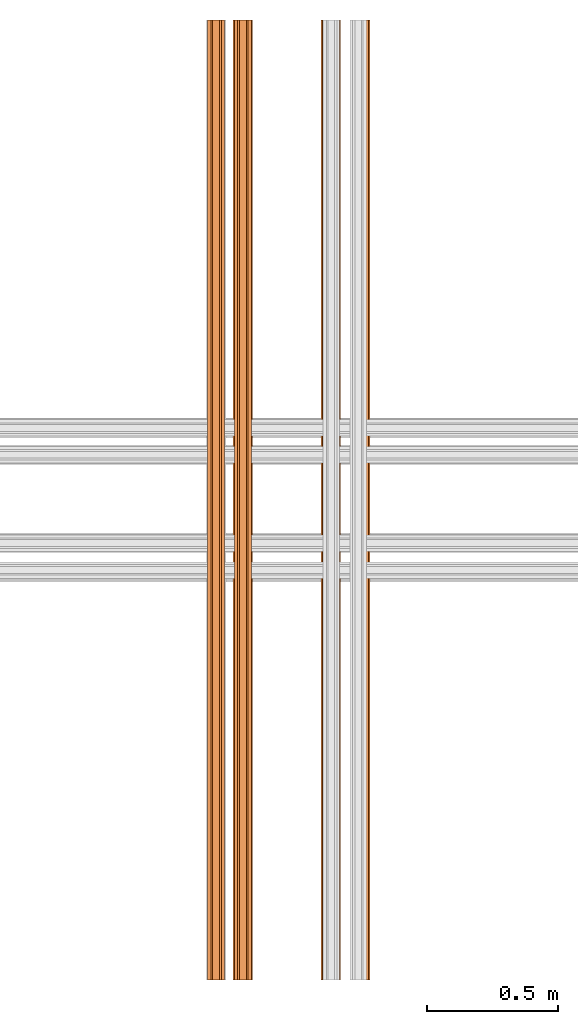
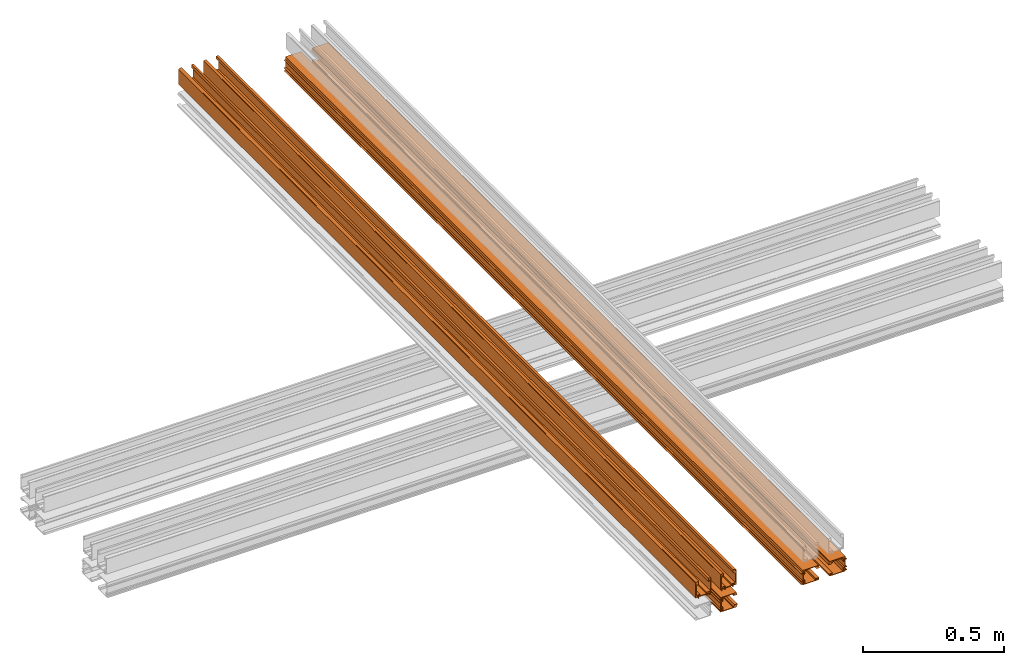
# One storey, part 3 of 4: 5 proxies.
"""IFC2X3 building model written with IfcOpenShell, lengths in feet."""

from ifc_helpers import new_model, entity, si_unit, converted_unit, derived_unit, direction, frame, origin, place, context, subcontext, project, spatial, polyline, outline, extrude, source, transform, mapped, material, type_object, type_shapes, element, save


model = new_model("IFC2X3")

# Units and contexts
model_context = context("Model", 3, precision=0.0001, world=origin(), true_north=direction((6.12303176911189e-17, 1.0)))
body_context = subcontext(model_context, "Body", "Model", "MODEL_VIEW")
ifc_project = project(units=[converted_unit("LENGTHUNIT", "FOOT", entity("IfcRatioMeasure", 0.3048), si_unit("LENGTHUNIT", "METRE"), dimensions=[1, 0, 0, 0, 0, 0, 0]), converted_unit("AREAUNIT", "SQUARE FOOT", entity("IfcRatioMeasure", 0.09290304), si_unit("AREAUNIT", "SQUARE_METRE"), dimensions=[2, 0, 0, 0, 0, 0, 0]), converted_unit("VOLUMEUNIT", "CUBIC FOOT", entity("IfcRatioMeasure", 0.028316846592), si_unit("VOLUMEUNIT", "CUBIC_METRE"), dimensions=[3, 0, 0, 0, 0, 0, 0]), converted_unit("PLANEANGLEUNIT", "DEGREE", entity("IfcRatioMeasure", 0.0174532925199433), si_unit("PLANEANGLEUNIT", "RADIAN"), dimensions=[0, 0, 0, 0, 0, 0, 0]), si_unit("MASSUNIT", "GRAM", prefix="KILO"), derived_unit("MASSDENSITYUNIT", [(si_unit("MASSUNIT", "GRAM", prefix="KILO"), 1), (si_unit("LENGTHUNIT", "METRE"), -3)]), si_unit("TIMEUNIT", "SECOND"), si_unit("FREQUENCYUNIT", "HERTZ"), si_unit("THERMODYNAMICTEMPERATUREUNIT", "DEGREE_CELSIUS"), derived_unit("THERMALTRANSMITTANCEUNIT", [(si_unit("MASSUNIT", "GRAM", prefix="KILO"), 1), (si_unit("THERMODYNAMICTEMPERATUREUNIT", "KELVIN"), -1), (si_unit("TIMEUNIT", "SECOND"), -3)]), derived_unit("VOLUMETRICFLOWRATEUNIT", [(si_unit("LENGTHUNIT", "METRE"), 3), (si_unit("TIMEUNIT", "SECOND"), -1)]), si_unit("ELECTRICCURRENTUNIT", "AMPERE"), si_unit("ELECTRICVOLTAGEUNIT", "VOLT"), si_unit("POWERUNIT", "WATT"), si_unit("FORCEUNIT", "NEWTON"), si_unit("ILLUMINANCEUNIT", "LUX"), si_unit("LUMINOUSFLUXUNIT", "LUMEN"), si_unit("LUMINOUSINTENSITYUNIT", "CANDELA"), derived_unit("USERDEFINED", [(si_unit("MASSUNIT", "GRAM", prefix="KILO"), -1), (si_unit("LENGTHUNIT", "METRE"), -2), (si_unit("TIMEUNIT", "SECOND"), 3), (si_unit("LUMINOUSFLUXUNIT", "LUMEN"), 1)]), derived_unit("LINEARVELOCITYUNIT", [(si_unit("LENGTHUNIT", "METRE"), 1), (si_unit("TIMEUNIT", "SECOND"), -1)]), si_unit("PRESSUREUNIT", "PASCAL"), derived_unit("USERDEFINED", [(si_unit("LENGTHUNIT", "METRE"), -2), (si_unit("MASSUNIT", "GRAM", prefix="KILO"), 1), (si_unit("TIMEUNIT", "SECOND"), -2)])], contexts=[model_context])

# Site, building, storey
site_placement = place(None, origin())
site = spatial("IfcSite", under=ifc_project, at=site_placement, CompositionType="ELEMENT")
building_placement = place(site_placement, origin())
building = spatial("IfcBuilding", under=site, at=building_placement, CompositionType="ELEMENT")
storey_placement = place(building_placement, origin())
storey = spatial("IfcBuildingStorey", under=building, at=storey_placement, Name="Level 1", CompositionType="ELEMENT", Elevation=0.0)

# Proxies
ifc_material = material(Name="THERMAL BROKEN ALUMINUM STOREFRONT FOR POLYCARBONATE")
building_element_proxy_type_1 = type_object("IfcBuildingElementProxyType", Name="Generic Models 2", PredefinedType="NOTDEFINED", material=ifc_material)
shared_shape_1 = source(origin(), body_context, "Body", "SweptSolid", [
    extrude(outline(polyline([(-0.10703462932325, -0.0730229494703186), (-0.10703462932325, -0.0580447359626438), (-0.113745897781071, -0.0580447359626439), (-0.118025006955696, -0.0623242255363627), (-0.112092207910207, -0.0623242255363626), (-0.112092207910207, -0.0671872818698964), (-0.11773967307098, -0.0704478474007053), (-0.125224643652343, -0.0704478474007053), (-0.131454279657517, -0.0675429204239743), (-0.131454279657516, -0.0623242255363626), (-0.124783598829804, -0.0623242255363625), (-0.125514243391176, -0.0580447359626438), (-0.142048634925557, -0.0580447359626438), (-0.140085232742292, -0.0813874063643331), (0.0647285203812249, -0.0813874063643332), (0.0647285203812249, -0.0697160711634884), (0.0853478792356715, -0.0697160711634884), (0.0853478792356715, -0.0631023145498281), (0.0647285203809975, -0.0631023145498281), (0.0647285203809975, -0.0273102199340562), (0.0853478792356714, -0.0273102199340561), (0.0853478792356714, -0.0206964633203958), (0.0647285203809975, -0.0206964633203958), (0.0647285203809975, 0.0812331974328894), (0.0853478792356714, 0.0812331974328894), (0.0853478792356715, 0.0878469540465497), (0.0647285203812249, 0.0878469540465497), (0.0647285203812249, 0.116052680781773), (0.0602545085540829, 0.116052680781773), (0.0585038082739668, 0.113329369234955), (0.0606435530609293, 0.110217013181205), (0.0606435530609293, 0.0878469540467771), (0.0563640634872105, 0.0835674644730583), (0.0563640634872105, 0.0713125625121714), (0.0388570606861709, 0.0713125625121714), (0.0388570606861709, 0.11546911402173), (0.033799482099214, 0.11546911402173), (0.033799482099214, 0.0646988058985111), (0.0563640634872105, 0.0646988058985111), (0.0563640634872105, -0.0203074188135494), (0.033799482099214, -0.0203074188135494), (0.033799482099214, -0.0730229494703186), (-0.10703462932325, -0.0730229494703186)]), holes=[polyline([(0.0577257192607181, -0.0710777269369961), (0.0388570606861709, -0.0710777269369962), (0.0388570606861709, -0.0273102199340561), (0.0577257192607181, -0.0273102199340561), (0.0577257192607181, -0.0710777269369961)])]), frame((0.0, -0.117978010729643, -0.219774108936509), z_axis=(-1.0, 0.0, 0.0), x_axis=(0.0, -1.0, 0.0)), (0.0, 0.0, -1.0), 12.0),
    extrude(outline(polyline([(-0.035458782064809, -0.0579874289764477), (-0.0371114306935174, -0.0606344277326353), (-0.0357721806658754, -0.0632292686235391), (-0.031816743337918, -0.0629517678914724), (-0.0277772795930219, -0.0651918706200437), (-0.0314564692543425, -0.0718263669125332), (-0.0224403589082052, -0.0768262913240348), (0.0801995988221891, 0.108259143706008), (0.0645489921835621, 0.116938257778831), (0.0595490677720606, 0.107922147432693), (0.0641808354764026, 0.104241425091677), (0.0513416446814549, 0.0931221172418145), (0.0445492945375557, 0.0808738163942812), (0.0511837908300452, 0.0771946267329605), (-0.0196641946988643, -0.0505619557187229), (-0.0545378290564904, -0.0312226254478621), (-0.056721084459942, -0.0351595792918119), (-0.0305624709345734, -0.0549725228627144), (-0.0322344006357109, -0.0579874289764477), (-0.035458782064809, -0.0579874289764477)])), frame((0.0, -0.105609361057676, -0.110462182965566), z_axis=(-1.0, 0.0, 0.0), x_axis=(0.0, 0.484973800275872, 0.874528680516527)), (0.0, 0.0, -1.0), 12.0),
    extrude(outline(polyline([(-0.0178285177675856, -0.015526027218707), (-0.0144209943882483, -0.015526027218707), (-0.0144209943882479, -0.00196676824874445), (-0.00206457119881486, -0.00196676824874474), (-0.00122137518562389, -0.00702594432743677), (0.0126070394294665, -0.00196676824874522), (0.027466410094602, -0.00196676824874559), (0.0274664100946021, 0.00198764102988874), (0.0102463757664154, 0.0219787153649705), (-0.0278297824565654, 0.0219787153649716), (-0.0178285177675856, -0.015526027218707)])), frame((0.0, 0.0141887616480401, -0.113644362338437), z_axis=(1.0, 0.0, 0.0), x_axis=(0.0, -1.0, 0.0)), (0.0, 0.0, 1.0), 12.0),
    extrude(outline(polyline([(-0.0292228042856086, -0.0158518272304064), (0.0188500922736237, -0.0158518272304064), (0.0188500922736237, -0.00589636662728305), (0.0115395937546053, -0.00589636662728303), (0.00550806035789696, 0.000135166769425191), (0.0129043470694794, 0.000135166769425221), (0.0129043470694794, 0.00370861456478623), (0.00801477925505999, 0.00653160785866194), (0.00118965299247949, 0.00653160785866197), (-0.00472072620232236, 0.00377555277752608), (-0.00472072620232237, 0.000414827901224118), (0.00196648946985058, 0.000414827901224151), (0.000888968452729204, -0.00589636662728305), (-0.0169597840697408, -0.0058963666272831), (-0.0150489881052633, 0.0168208742845054), (-0.0219433941035702, 0.0168208742845054), (-0.0292228042856086, -0.0158518272304064)])), frame((0.0, 0.00790671086723129, -0.28270850073431), z_axis=(1.0, 0.0, 0.0), x_axis=(0.0, -1.0, 0.0)), (0.0, 0.0, 1.0), 12.0),
])
type_shapes(building_element_proxy_type_1, [shared_shape_1])
proxy_1_placement = place(storey_placement, frame((6.81891280910475, -5.22796219089525, 1.25949484863417), z_axis=(0.0, 0.0, 1.0), x_axis=(0.0, 1.0, 0.0)))
element("IfcBuildingElementProxy", 1, at=proxy_1_placement, inside=storey, type_object=building_element_proxy_type_1, material=ifc_material, Name="Generic Models 11:Generic Models 2", ObjectType="Generic Models 11:Generic Models 2", context=body_context, shape_type="MappedRepresentation", body=[
    mapped(shared_shape_1, transform((0.0, 0.0, 0.0), scale=1.0)),
])
building_element_proxy_type_2 = type_object("IfcBuildingElementProxyType", Name="Generic Models 2", PredefinedType="NOTDEFINED", material=ifc_material)
shared_shape_2 = source(origin(), body_context, "Body", "SweptSolid", [
    extrude(outline(polyline([(-0.0730229494703184, 0.10703462932325), (-0.0580447359626436, 0.10703462932325), (-0.0580447359626437, 0.113745897781071), (-0.0623242255363624, 0.118025006955696), (-0.0623242255363625, 0.112092207910207), (-0.0671872818698961, 0.112092207910207), (-0.070447847400705, 0.11773967307098), (-0.070447847400705, 0.125224643652343), (-0.067542920423974, 0.131454279657517), (-0.0623242255363624, 0.131454279657517), (-0.0623242255363624, 0.124783598829804), (-0.0580447359626436, 0.125514243391176), (-0.0580447359626436, 0.142048634925557), (-0.0813874063643329, 0.140085232742292), (-0.0813874063643329, -0.0647285203812248), (-0.0697160711634882, -0.0647285203812248), (-0.0697160711634882, -0.0853478792356714), (-0.0631023145498278, -0.0853478792356714), (-0.0631023145498279, -0.0647285203809975), (-0.0273102199340559, -0.0647285203809975), (-0.0273102199340559, -0.0853478792356714), (-0.0206964633203955, -0.0853478792356714), (-0.0206964633203956, -0.0647285203809975), (0.0812331974328896, -0.0647285203809974), (0.0812331974328896, -0.0853478792356714), (0.08784695404655, -0.0853478792356713), (0.0878469540465499, -0.0647285203812248), (0.116052680781773, -0.0647285203812248), (0.116052680781773, -0.0602545085540828), (0.113329369234955, -0.0585038082739667), (0.110217013181205, -0.0606435530609292), (0.0878469540467774, -0.0606435530609292), (0.0835674644730585, -0.0563640634872104), (0.0713125625121717, -0.0563640634872104), (0.0713125625121716, -0.0388570606861709), (0.115469114021731, -0.0388570606861708), (0.115469114021731, -0.0337994820992139), (0.0646988058985113, -0.033799482099214), (0.0646988058985113, -0.0563640634872104), (-0.0203074188135491, -0.0563640634872104), (-0.0203074188135492, -0.033799482099214), (-0.0730229494703184, -0.033799482099214), (-0.0730229494703184, 0.10703462932325)]), holes=[polyline([(-0.0710777269369959, -0.0577257192607181), (-0.0710777269369959, -0.0388570606861708), (-0.0273102199340559, -0.0388570606861709), (-0.0273102199340559, -0.0577257192607181), (-0.0710777269369959, -0.0577257192607181)])]), frame((0.0, 0.276330802761896, -0.219774108936507), z_axis=(1.0, 0.0, 0.0), x_axis=(0.0, 0.0, 1.0)), (0.0, 0.0, 1.0), 12.0),
    extrude(outline(polyline([(0.0679666623619385, 0.000632417738883059), (0.0710872151823904, 0.000632417738883059), (0.0725790120391962, 0.00314266314992747), (0.0702488184526767, 0.00635088523716513), (0.0700096732994307, 0.0109637083615177), (0.0775858665392127, 0.0113564851588296), (0.0770520929428698, 0.0216523375102526), (-0.134304272308872, 0.0106948719853316), (-0.133377721915217, -0.00717717360587345), (-0.123081869563794, -0.00664340000953058), (-0.122412698736183, -0.000765203056202354), (-0.106181130798194, -0.0057672056155308), (-0.092194312509525, -0.00504207922050176), (-0.0925870893068369, 0.00253411401928028), (0.0533031958989614, 0.0100975851674494), (0.0553677918848117, -0.0297259946823085), (0.0598635549062837, -0.0294929183410433), (0.0628161856570255, 0.00318899968962212), (0.0662590259738257, 0.00336748877384826), (0.0679666623619385, 0.000632417738883059)])), frame((0.0, 0.263962153089929, -0.110462182965564), z_axis=(1.0, 0.0, 0.0), x_axis=(0.0, 0.99865882581399, -0.05177402460523)), (0.0, 0.0, 1.0), 12.0),
    extrude(outline(polyline([(-0.0104080468283572, -0.0212270141141865), (0.0284072982254618, -0.0212270141141865), (0.018596494374574, 0.0155635003266429), (-0.00515653981588794, 0.0270511459549447), (-0.00897742822638779, 0.0260322423788114), (-0.00514872339515059, 0.0116745992616716), (-0.00647401012520621, -0.00299045881680825), (-0.00136839731267844, -0.00250162354759877), (0.00181539143775596, -0.0144408313617281), (-0.0112860383341236, -0.0179345459675626), (-0.0104080468283572, -0.0212270141141865)])), frame((0.0, 0.144164030384213, -0.113644362338435), z_axis=(1.0, 0.0, 0.0), x_axis=(0.0, -0.257662650560335, -0.966234939601246)), (0.0, 0.0, 1.0), 12.0),
    extrude(outline(polyline([(-0.0218274236802371, -0.0250762096884888), (0.0116463755794956, -0.0250762096884888), (0.0131456738465899, -0.018346801187307), (-0.00944342914962784, -0.015271642380292), (-0.00556193395869958, 0.00214995231397121), (0.000832544625431163, 0.00182921635388846), (-0.000621696809064745, -0.00469796031725746), (0.00265859892029524, -0.00542880340721442), (0.00663400184610037, -0.000259219921661535), (0.00811823413249318, 0.0064025668521849), (0.00642611525779216, 0.0117890219260674), (0.00293818751194459, 0.0125661249989721), (0.00132974729935322, 0.00534684683544013), (-0.0032457860465378, 0.0125456859662899), (-0.00165600184121952, 0.0196812290274094), (-0.011373207534109, 0.0218462023164867), (-0.0218274236802371, -0.0250762096884888)])), frame((0.0, 0.150446081165022, -0.282708500734308), z_axis=(1.0, 0.0, 0.0), x_axis=(0.0, 0.217465908950317, -0.97606791692198)), (0.0, 0.0, 1.0), 12.0),
])
type_shapes(building_element_proxy_type_2, [shared_shape_2])
proxy_2_placement = place(storey_placement, frame((6.77203780910475, -5.22796219089525, 1.25949484863417), z_axis=(0.0, 0.0, 1.0), x_axis=(0.0, 1.0, 0.0)))
element("IfcBuildingElementProxy", 2, at=proxy_2_placement, inside=storey, type_object=building_element_proxy_type_2, material=ifc_material, Name="Generic Models 12:Generic Models 2", ObjectType="Generic Models 12:Generic Models 2", context=body_context, shape_type="MappedRepresentation", body=[
    mapped(shared_shape_2, transform((0.0, 0.0, 0.0), scale=1.0)),
])
building_element_proxy_type_3 = type_object("IfcBuildingElementProxyType", Name="Generic Models 2", PredefinedType="NOTDEFINED", material=ifc_material)
shared_shape_3 = source(origin(), body_context, "Body", "SweptSolid", [
    extrude(outline(polyline([(-0.0354587820648092, -0.0579874289764476), (-0.0371114306935175, -0.0606344277326351), (-0.0357721806658755, -0.0632292686235389), (-0.0318167433379183, -0.0629517678914723), (-0.0277772795930221, -0.0651918706200435), (-0.0314564692543428, -0.071826366912533), (-0.0224403589082054, -0.0768262913240346), (0.0801995988221894, 0.108259143706008), (0.0645489921835626, 0.11693825777883), (0.059549067772061, 0.107922147432693), (0.0641808354764031, 0.104241425091677), (0.0513416446814554, 0.0931221172418144), (0.0445492945375561, 0.080873816394281), (0.0511837908300456, 0.0771946267329603), (-0.0196641946988643, -0.0505619557187229), (-0.0545378290564905, -0.0312226254478618), (-0.0567210844599421, -0.0351595792918117), (-0.0305624709345735, -0.0549725228627142), (-0.0322344006357111, -0.0579874289764476), (-0.0354587820648092, -0.0579874289764476)])), frame((0.0, 1.24954979914876, 0.398878044208478), z_axis=(-1.0, 0.0, 0.0), x_axis=(0.0, -0.874528680516525, 0.484973800275877)), (0.0, 0.0, -1.0), 12.0),
    extrude(outline(polyline([(-0.0178285177675852, -0.0155260272187077), (-0.014420994388248, -0.0155260272187077), (-0.014420994388248, -0.00196676824874498), (-0.00206457119881487, -0.00196676824874498), (-0.00122137518562382, -0.00702594432743697), (0.0126070394294664, -0.00196676824874498), (0.0274664100946019, -0.00196676824874498), (0.0274664100946019, 0.00198764102988935), (0.0102463757664146, 0.0219787153649706), (-0.0278297824565662, 0.0219787153649706), (-0.0178285177675852, -0.0155260272187077)])), frame((0.0, 1.25273197852163, 0.518676166914195), z_axis=(1.0, 0.0, 0.0), x_axis=(0.0, 0.0, -1.0)), (0.0, 0.0, 1.0), 12.0),
    extrude(outline(polyline([(-0.10703462932325, -0.0730229494703184), (-0.10703462932325, -0.0580447359626436), (-0.113745897781071, -0.0580447359626436), (-0.118025006955696, -0.0623242255363625), (-0.112092207910207, -0.0623242255363624), (-0.112092207910207, -0.0671872818698961), (-0.11773967307098, -0.070447847400705), (-0.125224643652343, -0.070447847400705), (-0.131454279657516, -0.0675429204239741), (-0.131454279657516, -0.0623242255363625), (-0.124783598829804, -0.0623242255363625), (-0.125514243391176, -0.0580447359626437), (-0.142048634925556, -0.0580447359626437), (-0.140085232742292, -0.0813874063643329), (0.064728520381225, -0.0813874063643327), (0.064728520381225, -0.0697160711634881), (0.0853478792356716, -0.0697160711634881), (0.0853478792356715, -0.0631023145498277), (0.0647285203809976, -0.0631023145498277), (0.0647285203809976, -0.0273102199340558), (0.0853478792356715, -0.0273102199340558), (0.0853478792356715, -0.0206964633203954), (0.0647285203809976, -0.0206964633203954), (0.0647285203809974, 0.0812331974328897), (0.0853478792356714, 0.0812331974328897), (0.0853478792356713, 0.0878469540465501), (0.0647285203812248, 0.0878469540465501), (0.0647285203812248, 0.116052680781773), (0.0602545085540827, 0.116052680781773), (0.0585038082739666, 0.113329369234955), (0.0606435530609292, 0.110217013181205), (0.0606435530609292, 0.0878469540467774), (0.0563640634872104, 0.0835674644730586), (0.0563640634872104, 0.0713125625121717), (0.0388570606861708, 0.0713125625121717), (0.0388570606861708, 0.115469114021731), (0.0337994820992139, 0.115469114021731), (0.0337994820992139, 0.0646988058985113), (0.0563640634872104, 0.0646988058985114), (0.0563640634872105, -0.0203074188135491), (0.0337994820992141, -0.0203074188135491), (0.0337994820992141, -0.0730229494703184), (-0.10703462932325, -0.0730229494703184)]), holes=[polyline([(0.0577257192607182, -0.0710777269369958), (0.038857060686171, -0.0710777269369959), (0.0388570606861709, -0.0273102199340559), (0.0577257192607182, -0.0273102199340558), (0.0577257192607182, -0.0710777269369958)])]), frame((0.0, 1.3588617251197, 0.386509394536512), z_axis=(-1.0, 0.0, 0.0), x_axis=(0.0, 0.0, -1.0)), (0.0, 0.0, -1.0), 12.0),
    extrude(outline(polyline([(-0.0292228042856085, -0.0158518272304069), (0.0188500922736238, -0.0158518272304069), (0.0188500922736238, -0.00589636662728354), (0.0115395937546053, -0.00589636662728354), (0.00550806035789708, 0.000135166769424711), (0.0129043470694795, 0.000135166769424711), (0.0129043470694794, 0.00370861456478577), (0.00801477925506, 0.00653160785866147), (0.00118965299247953, 0.00653160785866147), (-0.00472072620232233, 0.00377555277752561), (-0.00472072620232233, 0.000414827901223713), (0.00196648946985067, 0.000414827901223713), (0.000888968452729344, -0.00589636662728354), (-0.0169597840697407, -0.00589636662728354), (-0.0150489881052633, 0.0168208742845049), (-0.0219433941035703, 0.0168208742845049), (-0.0292228042856085, -0.0158518272304069)])), frame((0.0, 1.42179611691751, 0.512394116133386), z_axis=(1.0, 0.0, 0.0), x_axis=(0.0, 0.0, -1.0)), (0.0, 0.0, 1.0), 12.0),
])
type_shapes(building_element_proxy_type_3, [shared_shape_3])
proxy_3_placement = place(storey_placement, frame((6.77203780910475, -5.22796219089525, 0.958333333333333), z_axis=(0.0, 0.0, 1.0), x_axis=(0.0, 1.0, 0.0)))
element("IfcBuildingElementProxy", 3, at=proxy_3_placement, inside=storey, type_object=building_element_proxy_type_3, material=ifc_material, Name="Generic Models 13:Generic Models 2", ObjectType="Generic Models 13:Generic Models 2", context=body_context, shape_type="MappedRepresentation", body=[
    mapped(shared_shape_3, transform((0.0, 0.0, 0.0), scale=1.0)),
])
building_element_proxy_type_4 = type_object("IfcBuildingElementProxyType", Name="Generic Models 2", PredefinedType="NOTDEFINED", material=ifc_material)
shared_shape_4 = source(origin(), body_context, "Body", "SweptSolid", [
    extrude(outline(polyline([(0.0679666623619384, 0.000632417738882034), (0.0710872151823903, 0.000632417738882035), (0.0725790120391962, 0.00314266314992642), (0.0702488184526767, 0.00635088523716412), (0.0700096732994308, 0.0109637083615167), (0.0775858665392128, 0.0113564851588285), (0.07705209294287, 0.0216523375102514), (-0.134304272308872, 0.0106948719853338), (-0.133377721915217, -0.00717717360587119), (-0.123081869563794, -0.00664340000952841), (-0.122412698736183, -0.000765203056200247), (-0.106181130798194, -0.00576720561552883), (-0.0921943125095251, -0.0050420792205001), (-0.0925870893068369, 0.002534114019282), (0.0533031958989615, 0.0100975851674486), (0.0553677918848111, -0.0297259946823094), (0.0598635549062831, -0.0294929183410442), (0.0628161856570255, 0.00318899968962119), (0.0662590259738256, 0.00336748877384732), (0.0679666623619384, 0.000632417738882034)])), frame((-15.047462540598, 0.320001633810749, 0.0977165289076384), z_axis=(1.0, 0.0, 0.0), x_axis=(0.0, -0.0517740246052117, -0.998658825813991)), (0.0, 0.0, 1.0), 12.0),
    extrude(outline(polyline([(-0.0104080468283571, -0.0212270141141864), (0.0284072982254619, -0.0212270141141864), (0.018596494374574, 0.0155635003266429), (-0.00515653981588799, 0.0270511459549446), (-0.00897742822638784, 0.0260322423788113), (-0.00514872339515063, 0.0116745992616715), (-0.00647401012520614, -0.00299045881680826), (-0.00136839731267838, -0.00250162354759878), (0.00181539143775607, -0.014440831361728), (-0.0112860383341234, -0.0179345459675626), (-0.0104080468283571, -0.0212270141141864)])), frame((-15.047462540598, 0.316819454437877, 0.217514651613355), z_axis=(1.0, 0.0, 0.0), x_axis=(0.0, -0.966234939601246, 0.257662650560335)), (0.0, 0.0, 1.0), 12.0),
    extrude(outline(polyline([(-0.0730229494703183, 0.10703462932325), (-0.0580447359626435, 0.10703462932325), (-0.0580447359626435, 0.113745897781071), (-0.0623242255363624, 0.118025006955696), (-0.0623242255363624, 0.112092207910207), (-0.067187281869896, 0.112092207910207), (-0.0704478474007049, 0.11773967307098), (-0.0704478474007049, 0.125224643652343), (-0.0675429204239739, 0.131454279657517), (-0.0623242255363623, 0.131454279657517), (-0.0623242255363623, 0.124783598829804), (-0.0580447359626435, 0.125514243391176), (-0.0580447359626435, 0.142048634925557), (-0.0813874063643328, 0.140085232742292), (-0.0813874063643332, -0.0647285203812247), (-0.0697160711634885, -0.0647285203812247), (-0.0697160711634885, -0.0853478792356713), (-0.0631023145498282, -0.0853478792356713), (-0.0631023145498281, -0.0647285203809973), (-0.0273102199340562, -0.0647285203809974), (-0.0273102199340562, -0.0853478792356714), (-0.0206964633203959, -0.0853478792356714), (-0.0206964633203958, -0.0647285203809974), (0.0812331974328893, -0.0647285203809976), (0.0812331974328893, -0.0853478792356715), (0.0878469540465496, -0.0853478792356716), (0.0878469540465497, -0.064728520381225), (0.116052680781773, -0.0647285203812251), (0.116052680781773, -0.060254508554083), (0.113329369234955, -0.058503808273967), (0.110217013181205, -0.0606435530609294), (0.0878469540467771, -0.0606435530609294), (0.0835674644730583, -0.0563640634872106), (0.0713125625121714, -0.0563640634872106), (0.0713125625121714, -0.038857060686171), (0.11546911402173, -0.0388570606861711), (0.11546911402173, -0.0337994820992142), (0.064698805898511, -0.0337994820992141), (0.064698805898511, -0.0563640634872106), (-0.0203074188135494, -0.0563640634872104), (-0.0203074188135494, -0.0337994820992139), (-0.0730229494703186, -0.0337994820992139), (-0.0730229494703183, 0.10703462932325)]), holes=[polyline([(-0.0710777269369962, -0.057725719260718), (-0.0710777269369961, -0.0388570606861708), (-0.0273102199340561, -0.0388570606861708), (-0.0273102199340562, -0.057725719260718), (-0.0710777269369962, -0.057725719260718)])]), frame((-15.047462540598, 0.210689707839806, 0.0853478792356716), z_axis=(1.0, 0.0, 0.0), x_axis=(0.0, 1.0, 0.0)), (0.0, 0.0, 1.0), 12.0),
    extrude(outline(polyline([(-0.0218274236802372, -0.0250762096884888), (0.0116463755794956, -0.0250762096884888), (0.0131456738465899, -0.018346801187307), (-0.00944342914962784, -0.0152716423802919), (-0.00556193395869953, 0.00214995231397128), (0.000832544625431264, 0.00182921635388849), (-0.000621696809064671, -0.00469796031725742), (0.00265859892029523, -0.00542880340721438), (0.00663400184610042, -0.000259219921661488), (0.00811823413249322, 0.00640256685218494), (0.00642611525779217, 0.0117890219260675), (0.00293818751194471, 0.0125661249989722), (0.00132974729935327, 0.00534684683544014), (-0.00324578604653776, 0.01254568596629), (-0.00165600184121945, 0.0196812290274095), (-0.0113732075341089, 0.0218462023164868), (-0.0218274236802372, -0.0250762096884888)])), frame((-15.047462540598, 0.147755316042005, 0.211232600832546), z_axis=(1.0, 0.0, 0.0), x_axis=(0.0, -0.976067916921979, -0.217465908950321)), (0.0, 0.0, 1.0), 12.0),
])
type_shapes(building_element_proxy_type_4, [shared_shape_4])
proxy_4_placement = place(storey_placement, frame((5.33178867762071, 9.81950034970276, 1.25949484863417), z_axis=(0.0, 0.0, 1.0), x_axis=(0.0, 1.0, 0.0)))
element("IfcBuildingElementProxy", 4, at=proxy_4_placement, inside=storey, type_object=building_element_proxy_type_4, material=ifc_material, Name="Generic Models 14:Generic Models 2", ObjectType="Generic Models 14:Generic Models 2", context=body_context, shape_type="MappedRepresentation", body=[
    mapped(shared_shape_4, transform((0.0, 0.0, 0.0), scale=1.0)),
])
building_element_proxy_type_5 = type_object("IfcBuildingElementProxyType", Name="Generic Models 2", PredefinedType="NOTDEFINED", material=ifc_material)
shared_shape_5 = source(origin(), body_context, "Body", "SweptSolid", [
    extrude(outline(polyline([(-0.0178285177675846, -0.0155260272187081), (-0.0144209943882473, -0.0155260272187081), (-0.0144209943882478, -0.00196676824874534), (-0.00206457119881464, -0.00196676824874493), (-0.00122137518562342, -0.00702594432743685), (0.0126070394294666, -0.0019667682487444), (0.0274664100946021, -0.00196676824874392), (0.027466410094602, 0.00198764102989041), (0.0102463757664141, 0.0219787153649712), (-0.0278297824565667, 0.0219787153649699), (-0.0178285177675846, -0.0155260272187081)])), frame((-15.047462540598, -0.420840541578669, -0.488678668263246), z_axis=(1.0, 0.0, 0.0), x_axis=(0.0, 1.0, 0.0)), (0.0, 0.0, 1.0), 12.0),
    extrude(outline(polyline([(-0.0354587820648082, -0.0579874289764482), (-0.0371114306935165, -0.0606344277326359), (-0.0357721806658744, -0.0632292686235396), (-0.0318167433379171, -0.0629517678914729), (-0.0277772795930209, -0.0651918706200441), (-0.0314564692543414, -0.0718263669125336), (-0.0224403589082041, -0.076826291324035), (0.0801995988221872, 0.10825914370601), (0.0645489921835603, 0.116938257778832), (0.0595490677720589, 0.107922147432694), (0.064180835476401, 0.104241425091678), (0.0513416446814535, 0.0931221172418154), (0.0445492945375544, 0.0808738163942819), (0.0511837908300439, 0.0771946267329613), (-0.0196641946988635, -0.0505619557187232), (-0.0545378290564898, -0.0312226254478629), (-0.0567210844599414, -0.0351595792918129), (-0.0305624709345725, -0.0549725228627149), (-0.03223440063571, -0.0579874289764482), (-0.0354587820648082, -0.0579874289764482)])), frame((-15.047462540598, -0.301042418872953, -0.491860847636118), z_axis=(-1.0, 0.0, 0.0), x_axis=(0.0, -0.484973800275861, -0.874528680516533)), (0.0, 0.0, -1.0), 12.0),
    extrude(outline(polyline([(-0.10703462932325, -0.073022949470319), (-0.10703462932325, -0.0580447359626442), (-0.113745897781071, -0.0580447359626442), (-0.118025006955696, -0.062324225536363), (-0.112092207910207, -0.0623242255363631), (-0.112092207910207, -0.0671872818698967), (-0.11773967307098, -0.0704478474007056), (-0.125224643652343, -0.0704478474007056), (-0.131454279657517, -0.0675429204239747), (-0.131454279657517, -0.062324225536363), (-0.124783598829804, -0.062324225536363), (-0.125514243391176, -0.0580447359626443), (-0.142048634925557, -0.0580447359626443), (-0.140085232742292, -0.0813874063643334), (0.0647285203812248, -0.0813874063643335), (0.0647285203812249, -0.0697160711634889), (0.0853478792356714, -0.0697160711634888), (0.0853478792356714, -0.0631023145498285), (0.0647285203809975, -0.0631023145498285), (0.0647285203809975, -0.0273102199340566), (0.0853478792356714, -0.0273102199340566), (0.0853478792356714, -0.0206964633203962), (0.0647285203809975, -0.0206964633203962), (0.0647285203809975, 0.0812331974328889), (0.0853478792356714, 0.0812331974328889), (0.0853478792356714, 0.0878469540465494), (0.0647285203812249, 0.0878469540465494), (0.0647285203812249, 0.116052680781772), (0.0602545085540828, 0.116052680781772), (0.0585038082739668, 0.113329369234955), (0.0606435530609293, 0.110217013181204), (0.0606435530609293, 0.0878469540467767), (0.0563640634872104, 0.0835674644730579), (0.0563640634872104, 0.071312562512171), (0.0388570606861709, 0.071312562512171), (0.0388570606861709, 0.11546911402173), (0.033799482099214, 0.11546911402173), (0.033799482099214, 0.0646988058985107), (0.0563640634872105, 0.0646988058985107), (0.0563640634872105, -0.0203074188135498), (0.033799482099214, -0.0203074188135498), (0.033799482099214, -0.073022949470319), (-0.10703462932325, -0.073022949470319)]), holes=[polyline([(0.0577257192607181, -0.0710777269369965), (0.0388570606861709, -0.0710777269369965), (0.0388570606861709, -0.0273102199340565), (0.0577257192607181, -0.0273102199340565), (0.0577257192607181, -0.0710777269369965)])]), frame((-15.047462540598, -0.288673769200986, -0.382548921665175), z_axis=(-1.0, 0.0, 0.0), x_axis=(0.0, 1.0, 0.0)), (0.0, 0.0, -1.0), 12.0),
    extrude(outline(polyline([(-0.0292228042856086, -0.0158518272304065), (0.0188500922736236, -0.0158518272304065), (0.0188500922736236, -0.00589636662728316), (0.0115395937546052, -0.00589636662728316), (0.00550806035789692, 0.000135166769425155), (0.0129043470694794, 0.000135166769425099), (0.0129043470694794, 0.00370861456478611), (0.00801477925505995, 0.00653160785866191), (0.00118965299247947, 0.00653160785866191), (-0.00472072620232239, 0.003775552777526), (-0.00472072620232239, 0.000414827901224046), (0.00196648946985056, 0.000414827901224102), (0.000888968452729122, -0.0058963666272831), (-0.0169597840697409, -0.00589636662728321), (-0.0150489881052634, 0.0168208742845053), (-0.0219433941035703, 0.0168208742845053), (-0.0292228042856086, -0.0158518272304065)])), frame((-15.047462540598, -0.41455849079786, -0.319614529867374), z_axis=(1.0, 0.0, 0.0), x_axis=(0.0, 1.0, 0.0)), (0.0, 0.0, 1.0), 12.0),
])
type_shapes(building_element_proxy_type_5, [shared_shape_5])
proxy_5_placement = place(storey_placement, frame((5.10784342880074, 9.81950034970276, 1.46782818196766), z_axis=(0.0, 0.0, 1.0), x_axis=(0.0, 1.0, 0.0)))
element("IfcBuildingElementProxy", 5, at=proxy_5_placement, inside=storey, type_object=building_element_proxy_type_5, material=ifc_material, Name="Generic Models 15:Generic Models 2", ObjectType="Generic Models 15:Generic Models 2", context=body_context, shape_type="MappedRepresentation", body=[
    mapped(shared_shape_5, transform((0.0, 0.0, 0.0), scale=1.0)),
])

save(model, "model.ifc")
